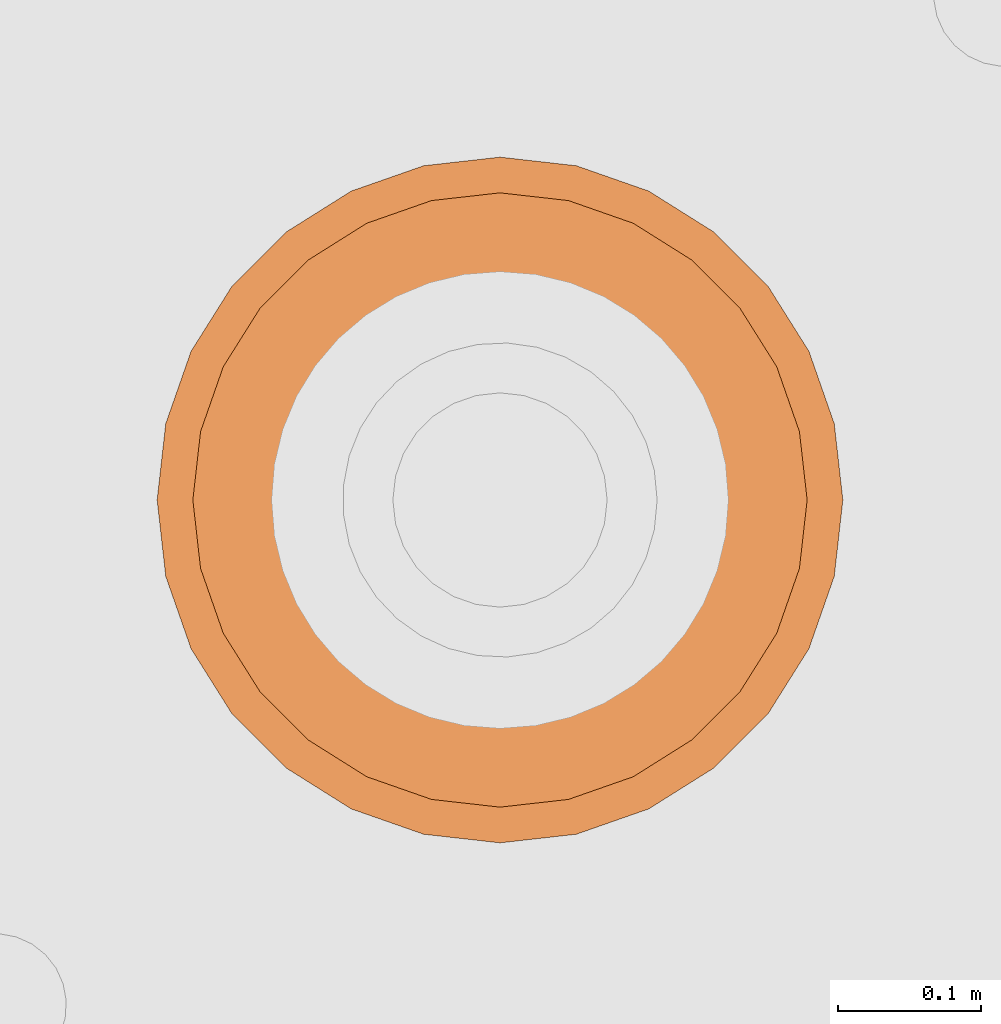
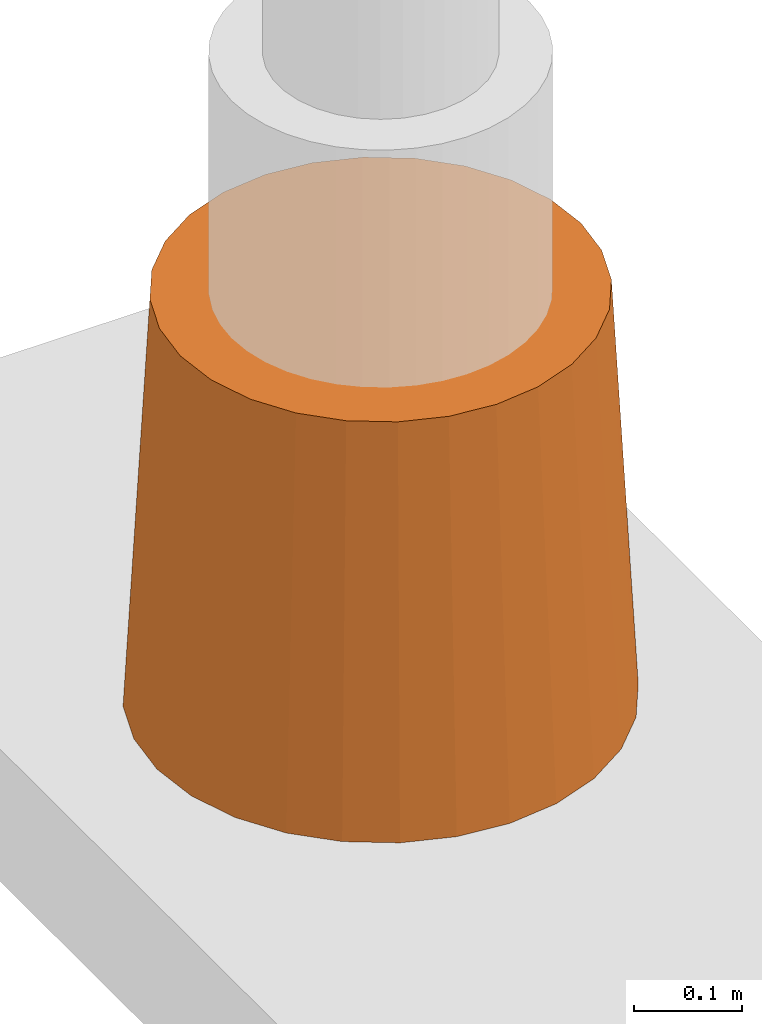
# One storey, part 5 of 5: 1 proxy.
"""IFC2X3 building model written with IfcOpenShell, lengths in millimetres."""

from ifc_helpers import new_model, entity, si_unit, converted_unit, direction, frame, origin_with_axes, place, context, project, spatial, faceted_brep, source, transform, mapped, element, save


model = new_model("IFC2X3")

# Units and contexts
model_context = context("Model", 3, precision=1e-05, world=origin_with_axes(), true_north=direction((0.0, 1.0)))
ifc_project = project(units=[si_unit("LENGTHUNIT", "METRE", prefix="MILLI"), si_unit("AREAUNIT", "SQUARE_METRE"), si_unit("VOLUMEUNIT", "CUBIC_METRE"), converted_unit("PLANEANGLEUNIT", "DEGREE", entity("IfcPlaneAngleMeasure", 0.017453293), si_unit("PLANEANGLEUNIT", "RADIAN"), dimensions=[0, 0, 0, 0, 0, 0, 0]), si_unit("SOLIDANGLEUNIT", "STERADIAN"), si_unit("MASSUNIT", "GRAM"), si_unit("TIMEUNIT", "SECOND"), si_unit("THERMODYNAMICTEMPERATUREUNIT", "DEGREE_CELSIUS"), si_unit("LUMINOUSINTENSITYUNIT", "LUMEN")], contexts=[model_context])

# Site, building, storey
site_placement = place(None, origin_with_axes())
site = spatial("IfcSite", under=ifc_project, at=site_placement, CompositionType="ELEMENT")
building_placement = place(site_placement, origin_with_axes())
building = spatial("IfcBuilding", under=site, at=building_placement, Name="Default Building", CompositionType="ELEMENT")
storey_placement = place(building_placement, frame((0.0, 0.0, 8000.0), z_axis=(0.0, 0.0, 1.0), x_axis=(1.0, 0.0, 0.0)))
storey = spatial("IfcBuildingStorey", under=building, at=storey_placement, Name="2FL", CompositionType="ELEMENT", Elevation=8000.0)

# Proxy
shared_shape = source(origin_with_axes(), model_context, "Body", "Brep", [
    faceted_brep([(240.0, 0.0, 0.0), (233.982697, 53.405025, 0.0), (209.609497, 47.841999, 460.0), (215.0, 0.0, 460.0), (216.232529, 104.132095, 0.0), (193.708313, 93.285004, 460.0), (187.639557, 149.637558, 0.0), (168.093765, 134.050308, 460.0), (149.637558, 187.639557, 0.0), (134.050308, 168.093765, 460.0), (104.132095, 216.232529, 0.0), (93.285004, 193.708313, 460.0), (53.405025, 233.982697, 0.0), (47.841999, 209.609497, 460.0), (0.0, 240.0, 0.0), (0.0, 215.0, 460.0), (-53.405025, 233.982697, 0.0), (-47.841999, 209.609497, 460.0), (-104.132095, 216.232529, 0.0), (-93.285004, 193.708313, 460.0), (-149.637558, 187.639557, 0.0), (-134.050308, 168.093765, 460.0), (-187.639557, 149.637558, 0.0), (-168.093765, 134.050308, 460.0), (-216.232529, 104.132095, 0.0), (-193.708313, 93.285004, 460.0), (-233.982697, 53.405025, 0.0), (-209.609497, 47.841999, 460.0), (-240.0, 0.0, 0.0), (-215.0, 0.0, 460.0), (-233.982697, -53.405025, 0.0), (-209.609497, -47.841999, 460.0), (-216.232529, -104.132095, 0.0), (-193.708313, -93.285004, 460.0), (-187.639557, -149.637558, 0.0), (-168.093765, -134.050308, 460.0), (-149.637558, -187.639557, 0.0), (-134.050308, -168.093765, 460.0), (-104.132095, -216.232529, 0.0), (-93.285004, -193.708313, 460.0), (-53.405025, -233.982697, 0.0), (-47.841999, -209.609497, 460.0), (0.0, -240.0, 0.0), (0.0, -215.0, 460.0), (53.405025, -233.982697, 0.0), (47.841999, -209.609497, 460.0), (104.132095, -216.232529, 0.0), (93.285004, -193.708313, 460.0), (149.637558, -187.639557, 0.0), (134.050308, -168.093765, 460.0), (187.639557, -149.637558, 0.0), (168.093765, -134.050308, 460.0), (216.232529, -104.132095, 0.0), (193.708313, -93.285004, 460.0), (233.982697, -53.405025, 0.0), (209.609497, -47.841999, 460.0), (0.0, 0.0, 0.0), (0.0, 0.0, 460.0)], [[[0, 1, 2, 3]], [[1, 4, 5, 2]], [[4, 6, 7, 5]], [[6, 8, 9, 7]], [[8, 10, 11, 9]], [[10, 12, 13, 11]], [[12, 14, 15, 13]], [[14, 16, 17, 15]], [[16, 18, 19, 17]], [[18, 20, 21, 19]], [[20, 22, 23, 21]], [[22, 24, 25, 23]], [[24, 26, 27, 25]], [[26, 28, 29, 27]], [[28, 30, 31, 29]], [[30, 32, 33, 31]], [[32, 34, 35, 33]], [[34, 36, 37, 35]], [[36, 38, 39, 37]], [[38, 40, 41, 39]], [[40, 42, 43, 41]], [[42, 44, 45, 43]], [[44, 46, 47, 45]], [[46, 48, 49, 47]], [[48, 50, 51, 49]], [[50, 52, 53, 51]], [[52, 54, 55, 53]], [[54, 0, 3, 55]], [[1, 0, 56, 4]], [[6, 4, 56, 8]], [[10, 8, 56, 12]], [[14, 12, 56, 16]], [[18, 16, 56, 20]], [[22, 20, 56, 24]], [[26, 24, 56, 28]], [[30, 28, 56, 32]], [[34, 32, 56, 36]], [[38, 36, 56, 40]], [[42, 40, 56, 44]], [[46, 44, 56, 48]], [[50, 48, 56, 52]], [[54, 52, 56, 0]], [[57, 3, 2, 5]], [[57, 5, 7, 9]], [[57, 9, 11, 13]], [[57, 13, 15, 17]], [[57, 17, 19, 21]], [[57, 21, 23, 25]], [[57, 25, 27, 29]], [[57, 29, 31, 33]], [[57, 33, 35, 37]], [[57, 37, 39, 41]], [[57, 41, 43, 45]], [[57, 45, 47, 49]], [[57, 49, 51, 53]], [[57, 53, 55, 3]]]),
])
proxy_placement = place(storey_placement, frame((53012.702942, 14305.649567, 4882.050808), z_axis=(0.0, 0.0, 1.0), x_axis=(1.0, 0.0, 0.0)))
element("IfcBuildingElementProxy", 1, at=proxy_placement, inside=storey, context=model_context, shape_type="MappedRepresentation", body=[
    mapped(shared_shape, transform((0.0, 0.0, 0.0))),
])

save(model, "model.ifc")
